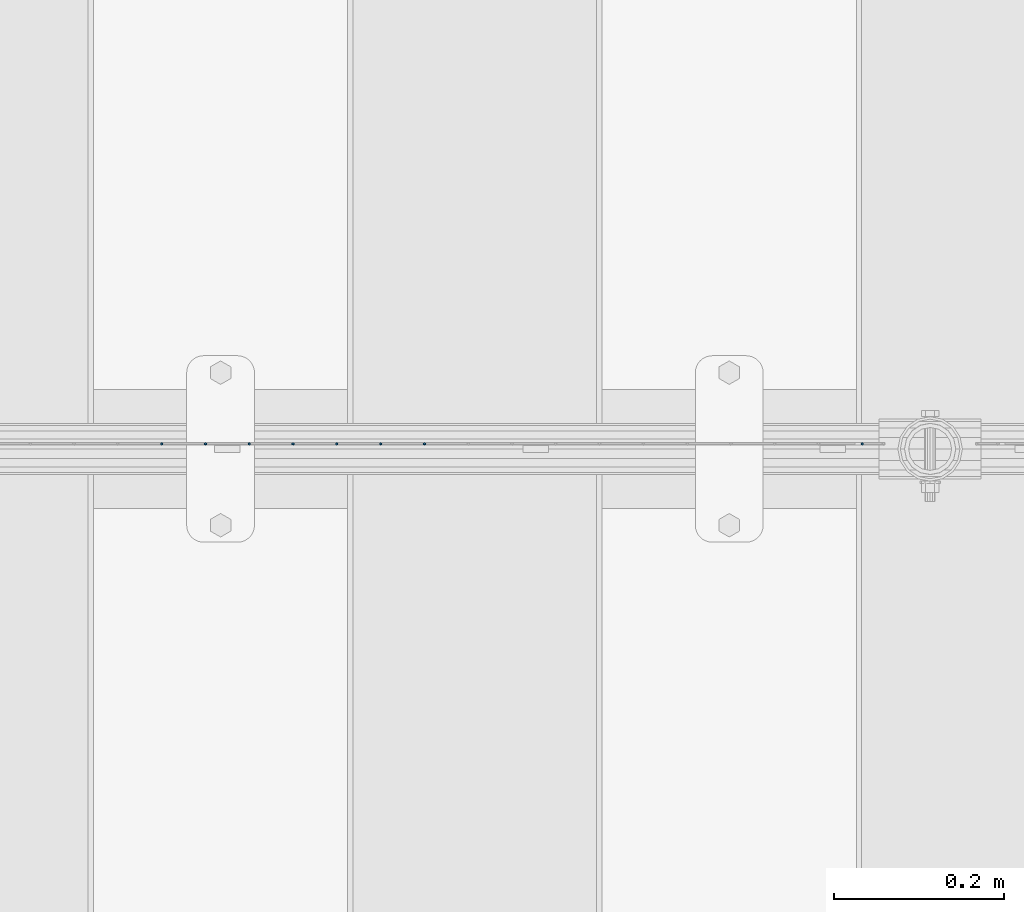
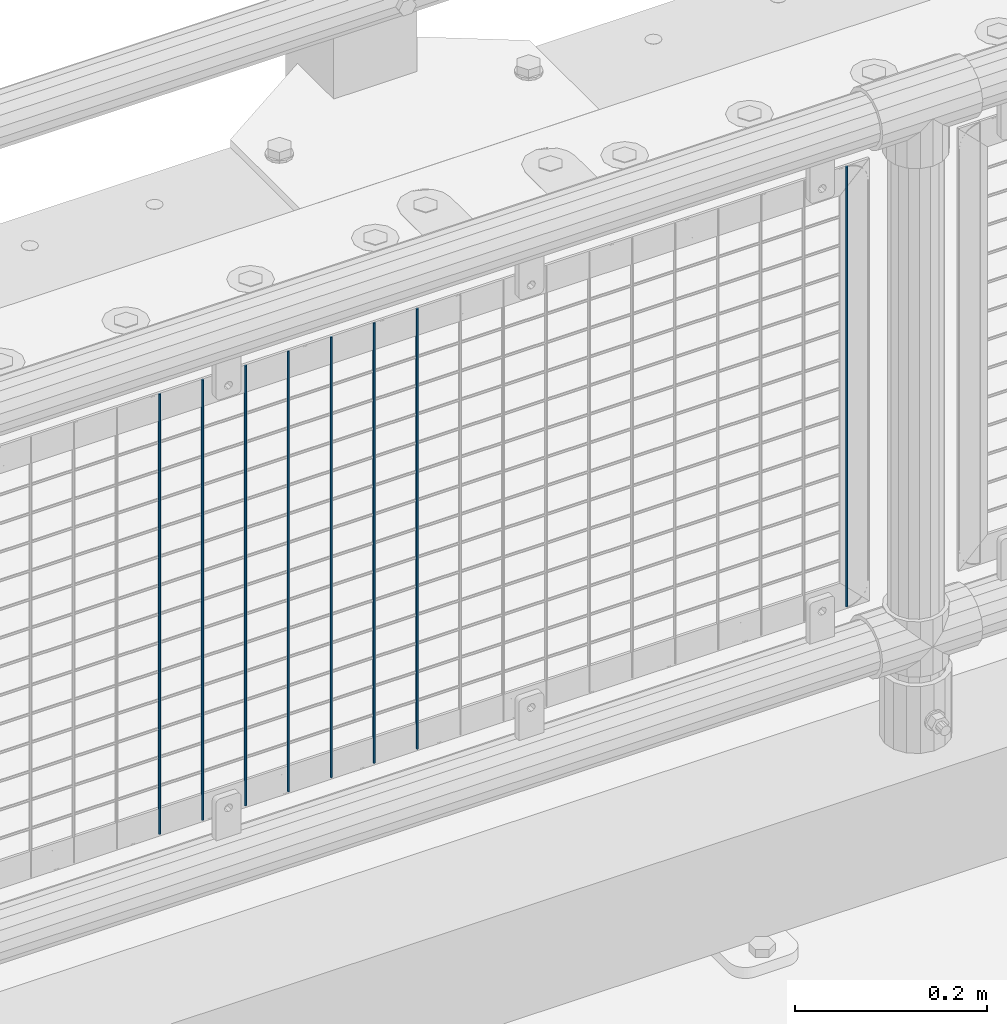
# One storey, part 70 of 219: 8 columns.
"""IFC2X3 building model written with IfcOpenShell, lengths in millimetres."""

from ifc_helpers import new_model, si_unit, frame, origin_with_axes, place, context, subcontext, project, spatial, faceted_brep, material, type_object, element, save


model = new_model("IFC2X3")

# Units and contexts
model_context = context("Model", 3, precision=1e-05, world=origin_with_axes())
body_context = subcontext(model_context, "Body", "Model", "MODEL_VIEW")
ifc_project = project(units=[si_unit("LENGTHUNIT", "METRE", prefix="MILLI"), si_unit("AREAUNIT", "SQUARE_METRE"), si_unit("VOLUMEUNIT", "CUBIC_METRE"), si_unit("MASSUNIT", "GRAM", prefix="KILO"), si_unit("TIMEUNIT", "SECOND"), si_unit("PLANEANGLEUNIT", "RADIAN"), si_unit("SOLIDANGLEUNIT", "STERADIAN"), si_unit("THERMODYNAMICTEMPERATUREUNIT", "DEGREE_CELSIUS"), si_unit("LUMINOUSINTENSITYUNIT", "LUMEN")], contexts=[model_context])

# Site, building, storey
site_placement = place(None, origin_with_axes())
site = spatial("IfcSite", under=ifc_project, at=site_placement, CompositionType="ELEMENT")
building_placement = place(site_placement, origin_with_axes())
building = spatial("IfcBuilding", under=site, at=building_placement, Name="Standard", CompositionType="ELEMENT")
storey_placement = place(building_placement, origin_with_axes())
storey = spatial("IfcBuildingStorey", under=building, at=storey_placement, Name="Undefined", CompositionType="ELEMENT", Elevation=0.0)

# Columns
ifc_material = material(Name="Misc_Undefined")
column_type = type_object("IfcColumnType", Name="D3", PredefinedType="NOTDEFINED")
for number, where, z_axis, x_axis in (
    (1, (3340.445, 31670.5, 353.02), (-1.0, 0.0, 0.0), (0.0, 0.0, 1.0)),
    (2, (3288.79, 31670.5, 353.02), (-1.0, 0.0, 0.0), (0.0, 0.0, 1.0)),
    (3, (3237.135, 31670.5, 353.02), (-1.0, 0.0, 0.0), (0.0, 0.0, 1.0)),
    (4, (3185.48, 31670.5, 353.02), (-1.0, 0.0, 0.0), (0.0, 0.0, 1.0)),
    (5, (3133.825, 31670.5, 353.02), (-1.0, 0.0, 0.0), (0.0, 0.0, 1.0)),
    (6, (3082.17, 31670.5, 353.02), (-1.0, 0.0, 0.0), (0.0, 0.0, 1.0)),
    (7, (3030.515, 31670.5, 353.02), (-1.0, 0.0, 0.0), (0.0, 0.0, 1.0)),
    (8, (3856.995, 31670.5, 353.02), (-1.0, 0.0, 0.0), (0.0, 0.0, 1.0)),
):
    element("IfcColumn", number, at=place(storey_placement, frame(where, z_axis=z_axis, x_axis=x_axis)), inside=storey, type_object=column_type, material=ifc_material, ObjectType="D3", context=body_context, shape_type="Brep", body=[
        faceted_brep([(0.0, -1.5, -5.6843418860808e-14), (0.0, -0.75, -1.29903810567669), (560.0, -0.75, -1.29903810567703), (560.0, -1.5, 0.0), (0.0, 0.75, -1.29903810567669), (560.0, 0.75, -1.29903810567703), (0.0, 1.5, -5.6843418860808e-14), (560.0, 1.5, 0.0), (0.0, 0.75, 1.29903810567669), (560.0, 0.75, 1.29903810567703), (0.0, -0.75, 1.29903810567669), (560.0, -0.75, 1.29903810567703)], [[[0, 1, 2, 3]], [[1, 4, 5, 2]], [[4, 6, 7, 5]], [[6, 8, 9, 7]], [[8, 10, 11, 9]], [[10, 0, 3, 11]], [[5, 7, 9, 11, 3, 2]], [[10, 8, 6, 4, 1, 0]]]),
    ])

save(model, "model.ifc")
